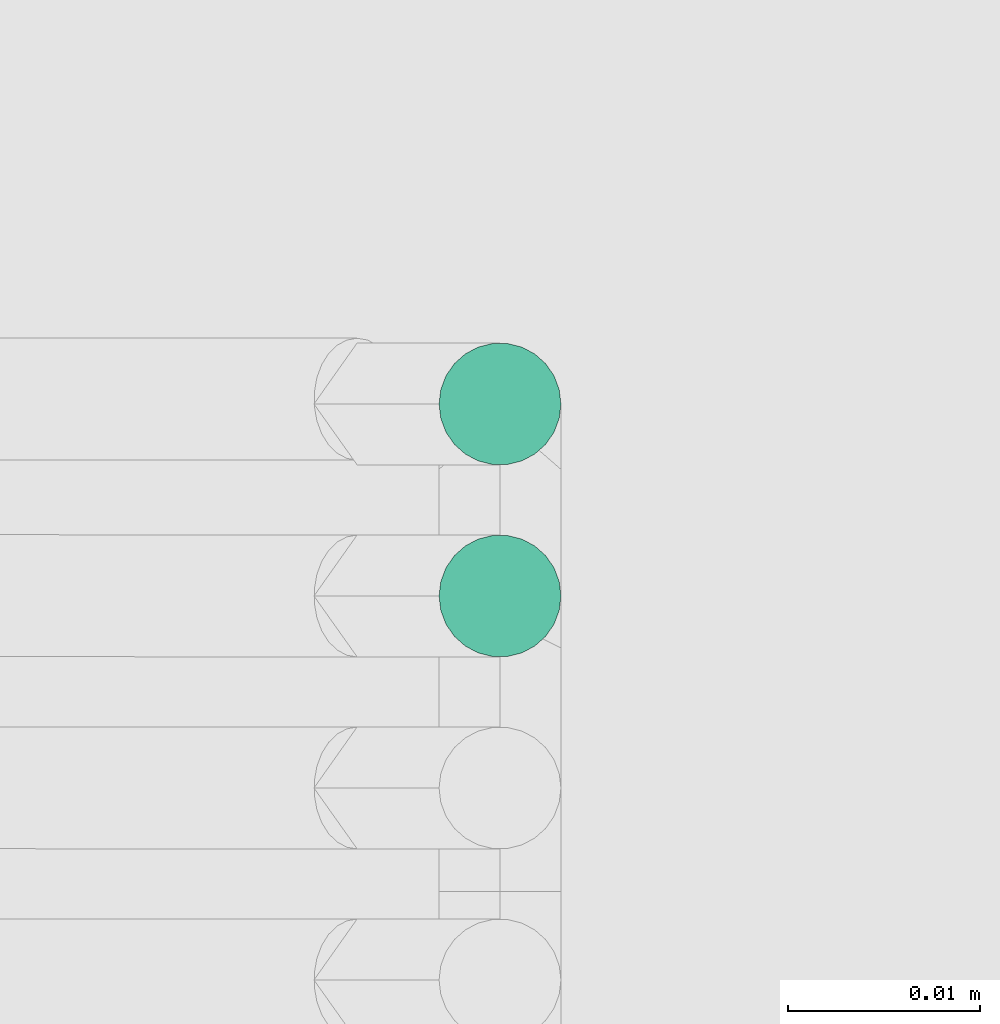
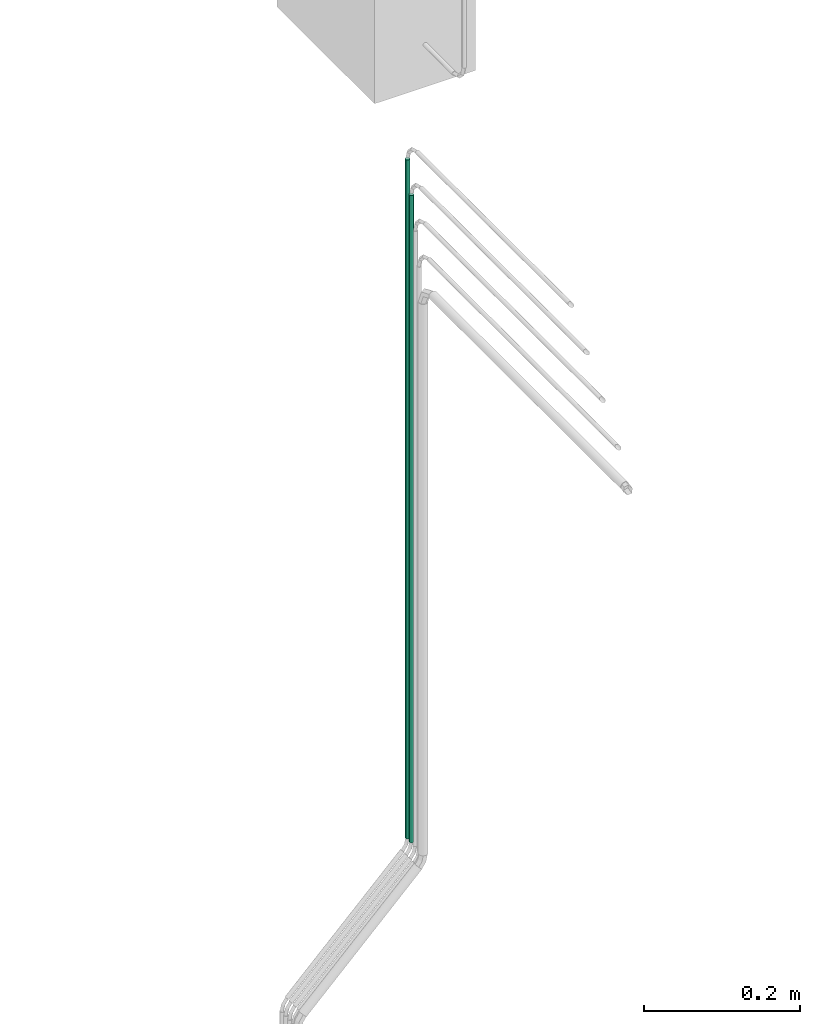
# One storey, part 2 of 45: 2 flow segments.
"""IFC2X3 building model written with IfcOpenShell, lengths in millimetres."""

from ifc_helpers import new_model, entity, si_unit, converted_unit, derived_unit, direction, frame, origin, origin_2d_with_axis, place, context, subcontext, project, spatial, circle, extrude, type_object, element, save


model = new_model("IFC2X3")

# Units and contexts
model_context = context("Model", 3, precision=0.01, world=origin(), true_north=direction((6.12303176911189e-17, 1.0)))
body_context = subcontext(model_context, "Body", "Model", "MODEL_VIEW")
ifc_project = project(units=[si_unit("LENGTHUNIT", "METRE", prefix="MILLI"), si_unit("AREAUNIT", "SQUARE_METRE"), si_unit("VOLUMEUNIT", "CUBIC_METRE"), converted_unit("PLANEANGLEUNIT", "DEGREE", entity("IfcRatioMeasure", 0.0174532925199433), si_unit("PLANEANGLEUNIT", "RADIAN"), dimensions=[0, 0, 0, 0, 0, 0, 0]), si_unit("MASSUNIT", "GRAM", prefix="KILO"), derived_unit("MASSDENSITYUNIT", [(si_unit("MASSUNIT", "GRAM", prefix="KILO"), 1), (si_unit("LENGTHUNIT", "METRE"), -3)]), derived_unit("MOMENTOFINERTIAUNIT", [(si_unit("LENGTHUNIT", "METRE"), 4)]), si_unit("TIMEUNIT", "SECOND"), si_unit("FREQUENCYUNIT", "HERTZ"), si_unit("THERMODYNAMICTEMPERATUREUNIT", "DEGREE_CELSIUS"), derived_unit("THERMALTRANSMITTANCEUNIT", [(si_unit("MASSUNIT", "GRAM", prefix="KILO"), 1), (si_unit("THERMODYNAMICTEMPERATUREUNIT", "KELVIN"), -1), (si_unit("TIMEUNIT", "SECOND"), -3)]), derived_unit("VOLUMETRICFLOWRATEUNIT", [(si_unit("LENGTHUNIT", "METRE"), 3), (si_unit("TIMEUNIT", "SECOND"), -1)]), derived_unit("MASSFLOWRATEUNIT", [(si_unit("MASSUNIT", "GRAM", prefix="KILO"), 1), (si_unit("TIMEUNIT", "SECOND"), -1)]), derived_unit("ROTATIONALFREQUENCYUNIT", [(si_unit("TIMEUNIT", "SECOND"), -1)]), si_unit("ELECTRICCURRENTUNIT", "AMPERE"), si_unit("ELECTRICVOLTAGEUNIT", "VOLT"), si_unit("POWERUNIT", "WATT"), si_unit("FORCEUNIT", "NEWTON", prefix="KILO"), si_unit("ILLUMINANCEUNIT", "LUX"), si_unit("LUMINOUSFLUXUNIT", "LUMEN"), si_unit("LUMINOUSINTENSITYUNIT", "CANDELA"), derived_unit("USERDEFINED", [(si_unit("MASSUNIT", "GRAM", prefix="KILO"), -1), (si_unit("LENGTHUNIT", "METRE"), -2), (si_unit("TIMEUNIT", "SECOND"), 3), (si_unit("LUMINOUSFLUXUNIT", "LUMEN"), 1)]), derived_unit("LINEARVELOCITYUNIT", [(si_unit("LENGTHUNIT", "METRE"), 1), (si_unit("TIMEUNIT", "SECOND"), -1)]), si_unit("PRESSUREUNIT", "PASCAL"), derived_unit("USERDEFINED", [(si_unit("LENGTHUNIT", "METRE"), -2), (si_unit("MASSUNIT", "GRAM", prefix="KILO"), 1), (si_unit("TIMEUNIT", "SECOND"), -2)]), derived_unit("LINEARFORCEUNIT", [(si_unit("MASSUNIT", "GRAM", prefix="KILO"), 1), (si_unit("LENGTHUNIT", "METRE"), 1), (si_unit("TIMEUNIT", "SECOND"), -2), (si_unit("LENGTHUNIT", "METRE"), -1)]), derived_unit("PLANARFORCEUNIT", [(si_unit("MASSUNIT", "GRAM", prefix="KILO"), 1), (si_unit("LENGTHUNIT", "METRE"), 1), (si_unit("TIMEUNIT", "SECOND"), -2), (si_unit("LENGTHUNIT", "METRE"), -2)])], contexts=[model_context])

# Site, building, storey
site_placement = place(None, frame((-24836.06, 8968.75, 0.0)))
site = spatial("IfcSite", under=ifc_project, at=site_placement, CompositionType="ELEMENT")
building_placement = place(site_placement, origin())
building = spatial("IfcBuilding", under=site, at=building_placement, CompositionType="ELEMENT")
storey_placement = place(building_placement, frame((0.0, 0.0, -4200.0)))
storey = spatial("IfcBuildingStorey", under=building, at=storey_placement, CompositionType="ELEMENT", Elevation=-4200.0)

# Flow segments
pipe_segment_type = type_object("IfcPipeSegmentType", PredefinedType="NOTDEFINED")
flow_segment_1_placement = place(storey_placement, frame((69646.14, -8368.67, 296.57)))
element("IfcFlowSegment", 1, at=flow_segment_1_placement, inside=storey, type_object=pipe_segment_type, context=body_context, shape_type="SweptSolid", body=[
    extrude(circle(Radius=3.175, at=origin_2d_with_axis()), frame((4.77, 4.77, 0.0), z_axis=(0.0, 0.0, 1.0), x_axis=(-1.0, 0.0, 0.0)), (0.0, 0.0, 1.0), 1014.07897551573),
])
flow_segment_2_placement = place(storey_placement, frame((69646.14, -8358.67, 296.57)))
element("IfcFlowSegment", 2, at=flow_segment_2_placement, inside=storey, type_object=pipe_segment_type, context=body_context, shape_type="SweptSolid", body=[
    extrude(circle(Radius=3.175, at=origin_2d_with_axis()), frame((4.77, 4.77, 0.0), z_axis=(0.0, 0.0, 1.0), x_axis=(-1.0, 0.0, 0.0)), (0.0, 0.0, 1.0), 1064.07897551572),
])

save(model, "model.ifc")
